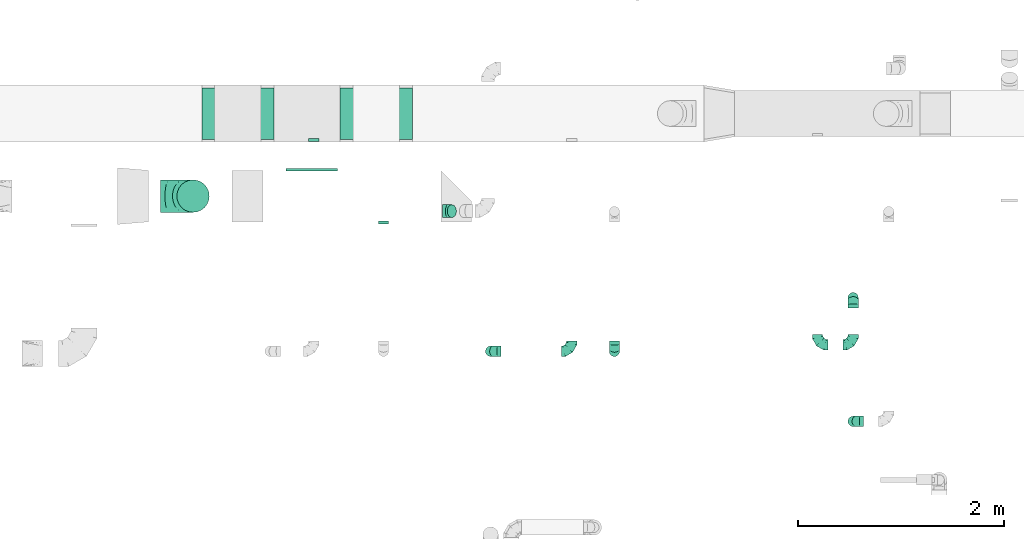
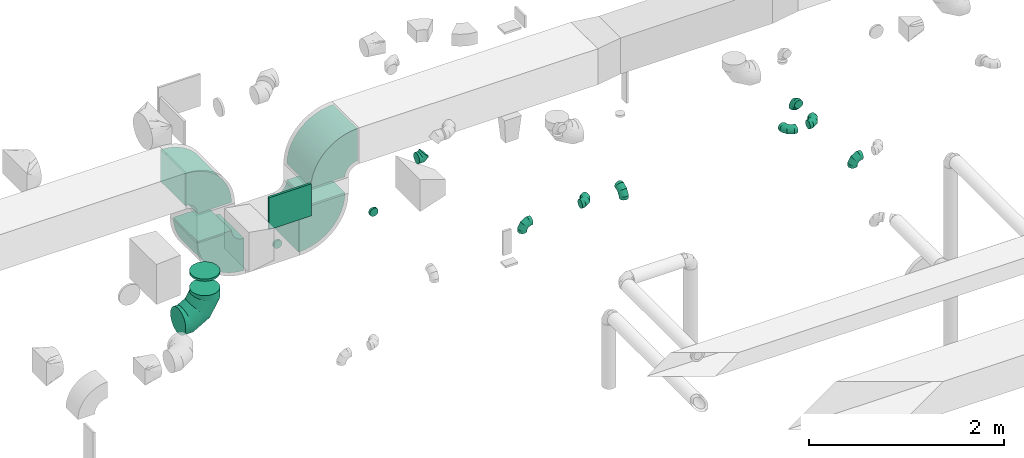
# One storey, part 60 of 97: 17 flow fittings.
"""IFC2X3 building model written with IfcOpenShell, lengths in millimetres."""

from ifc_helpers import new_model, entity, si_unit, converted_unit, derived_unit, direction, frame, frame_2d, origin, origin_2d_with_axis, place, context, subcontext, project, spatial, polyline, circle_curve, parameter, trimmed, segment, composite_curve, rectangle, outline, extrude, faceted_brep, source, transform, mapped, material, type_object, type_shapes, element, save


model = new_model("IFC2X3")

# Units and contexts
model_context = context("Model", 3, precision=0.01, world=origin(), true_north=direction((6.12303176911189e-17, 1.0)))
body_context = subcontext(model_context, "Body", "Model", "MODEL_VIEW")
ifc_project = project(units=[si_unit("LENGTHUNIT", "METRE", prefix="MILLI"), si_unit("AREAUNIT", "SQUARE_METRE"), si_unit("VOLUMEUNIT", "CUBIC_METRE"), converted_unit("PLANEANGLEUNIT", "DEGREE", entity("IfcRatioMeasure", 0.0174532925199433), si_unit("PLANEANGLEUNIT", "RADIAN"), dimensions=[0, 0, 0, 0, 0, 0, 0]), si_unit("MASSUNIT", "GRAM", prefix="KILO"), derived_unit("MASSDENSITYUNIT", [(si_unit("MASSUNIT", "GRAM", prefix="KILO"), 1), (si_unit("LENGTHUNIT", "METRE"), -3)]), derived_unit("MOMENTOFINERTIAUNIT", [(si_unit("LENGTHUNIT", "METRE"), 4)]), si_unit("TIMEUNIT", "SECOND"), si_unit("FREQUENCYUNIT", "HERTZ"), si_unit("THERMODYNAMICTEMPERATUREUNIT", "DEGREE_CELSIUS"), derived_unit("THERMALTRANSMITTANCEUNIT", [(si_unit("MASSUNIT", "GRAM", prefix="KILO"), 1), (si_unit("THERMODYNAMICTEMPERATUREUNIT", "KELVIN"), -1), (si_unit("TIMEUNIT", "SECOND"), -3)]), derived_unit("VOLUMETRICFLOWRATEUNIT", [(si_unit("LENGTHUNIT", "METRE"), 3), (si_unit("TIMEUNIT", "SECOND"), -1)]), derived_unit("MASSFLOWRATEUNIT", [(si_unit("MASSUNIT", "GRAM", prefix="KILO"), 1), (si_unit("TIMEUNIT", "SECOND"), -1)]), derived_unit("ROTATIONALFREQUENCYUNIT", [(si_unit("TIMEUNIT", "SECOND"), -1)]), si_unit("ELECTRICCURRENTUNIT", "AMPERE"), si_unit("ELECTRICVOLTAGEUNIT", "VOLT"), si_unit("POWERUNIT", "WATT"), si_unit("FORCEUNIT", "NEWTON", prefix="KILO"), si_unit("ILLUMINANCEUNIT", "LUX"), si_unit("LUMINOUSFLUXUNIT", "LUMEN"), si_unit("LUMINOUSINTENSITYUNIT", "CANDELA"), derived_unit("USERDEFINED", [(si_unit("MASSUNIT", "GRAM", prefix="KILO"), -1), (si_unit("LENGTHUNIT", "METRE"), -2), (si_unit("TIMEUNIT", "SECOND"), 3), (si_unit("LUMINOUSFLUXUNIT", "LUMEN"), 1)]), derived_unit("LINEARVELOCITYUNIT", [(si_unit("LENGTHUNIT", "METRE"), 1), (si_unit("TIMEUNIT", "SECOND"), -1)]), si_unit("PRESSUREUNIT", "PASCAL"), derived_unit("USERDEFINED", [(si_unit("LENGTHUNIT", "METRE"), -2), (si_unit("MASSUNIT", "GRAM", prefix="KILO"), 1), (si_unit("TIMEUNIT", "SECOND"), -2)]), derived_unit("LINEARFORCEUNIT", [(si_unit("MASSUNIT", "GRAM", prefix="KILO"), 1), (si_unit("LENGTHUNIT", "METRE"), 1), (si_unit("TIMEUNIT", "SECOND"), -2), (si_unit("LENGTHUNIT", "METRE"), -1)]), derived_unit("PLANARFORCEUNIT", [(si_unit("MASSUNIT", "GRAM", prefix="KILO"), 1), (si_unit("LENGTHUNIT", "METRE"), 1), (si_unit("TIMEUNIT", "SECOND"), -2), (si_unit("LENGTHUNIT", "METRE"), -2)])], contexts=[model_context])

# Site, building, storey
site_placement = place(None, origin())
site = spatial("IfcSite", under=ifc_project, at=site_placement, CompositionType="ELEMENT")
building_placement = place(site_placement, origin())
building = spatial("IfcBuilding", under=site, at=building_placement, CompositionType="ELEMENT")
storey_placement = place(building_placement, frame((0.0, 0.0, -4900.0)))
storey = spatial("IfcBuildingStorey", under=building, at=storey_placement, CompositionType="ELEMENT", Elevation=-4900.0)

# Flow fittings
ifc_material = material()
duct_fitting_type_1 = type_object("IfcDuctFittingType", PredefinedType="NOTDEFINED", material=ifc_material)
shared_shape_1 = source(origin(), body_context, "Body", "SweptSolid", [
    extrude(rectangle(XDim=500.0, YDim=26.0960000000433, at=origin_2d_with_axis()), frame((6.95, 0.0, -200.0), z_axis=(0.0, 0.0, 1.0), x_axis=(0.0, -1.0, 0.0)), (0.0, 0.0, 1.0), 400.0),
])
type_shapes(duct_fitting_type_1, [shared_shape_1])
flow_fitting_1_placement = place(storey_placement, frame((49419.33, 14798.39, 3800.0), z_axis=(0.0, 0.0, -1.0), x_axis=(0.0, 1.0, 0.0)))
element("IfcFlowFitting", 1, at=flow_fitting_1_placement, inside=storey, type_object=duct_fitting_type_1, material=ifc_material, context=body_context, shape_type="MappedRepresentation", body=[
    mapped(shared_shape_1, transform((0.0, 0.0, 0.0), scale=1.0)),
])
duct_fitting_type_2 = type_object("IfcDuctFittingType", PredefinedType="NOTDEFINED", material=ifc_material)
shared_shape_2 = source(origin(), body_context, "Body", "Brep", [
    faceted_brep([(-100.0, 0.0, -50.0), (-100.0, -12.94, -48.3), (-100.0, -25.0, -43.3), (-100.0, -35.36, -35.36), (-100.0, -43.3, -25.0), (-100.0, -48.3, -12.94), (-100.0, -50.0, 0.0), (-100.0, -48.3, 12.94), (-100.0, -43.3, 25.0), (-100.0, -35.36, 35.36), (-100.0, -25.0, 43.3), (-100.0, -12.94, 48.3), (-100.0, 0.0, 50.0), (-100.0, 12.94, 48.3), (-100.0, 25.0, 43.3), (-100.0, 35.36, 35.36), (-100.0, 43.3, 25.0), (-100.0, 48.3, 12.94), (-100.0, 50.0, 0.0), (-100.0, 48.3, -12.94), (-100.0, 43.3, -25.0), (-100.0, 35.36, -35.36), (-100.0, 25.0, -43.3), (-100.0, 12.94, -48.3), (-76.67, 12.94, 48.3), (-79.9, 25.0, 43.3), (-73.21, 0.0, 50.0), (-82.68, 35.36, 35.36), (-86.15, 48.3, 12.94), (-86.6, 50.0, 0.0), (-84.81, 43.3, 25.0), (-84.81, 43.3, -25.0), (-82.68, 35.36, -35.36), (-86.15, 48.3, -12.94), (-76.67, 12.94, -48.3), (-73.21, 0.0, -50.0), (-79.9, 25.0, -43.3), (-69.74, -12.94, -48.3), (-66.51, -25.0, -43.3), (-63.73, -35.36, -35.36), (-61.6, -43.3, -25.0), (-60.26, -48.3, -12.94), (-59.81, -50.0, 0.0), (-60.26, -48.3, 12.94), (-61.6, -43.3, 25.0), (-63.73, -35.36, 35.36), (-66.51, -25.0, 43.3), (-69.74, -12.94, 48.3), (-36.27, 36.27, 48.3), (-45.1, 45.1, 43.3), (-26.79, 26.79, 50.0), (-52.68, 52.68, 35.36), (-58.49, 58.49, 25.0), (-62.15, 62.15, 12.94), (-63.4, 63.4, 0.0), (-62.15, 62.15, -12.94), (-58.49, 58.49, -25.0), (-52.68, 52.68, -35.36), (-36.27, 36.27, -48.3), (-26.79, 26.79, -50.0), (-45.1, 45.1, -43.3), (-17.32, 17.32, -48.3), (-8.49, 8.49, -43.3), (-0.91, 0.91, -35.36), (4.9, -4.9, -25.0), (8.56, -8.56, -12.94), (9.81, -9.81, 0.0), (8.56, -8.56, 12.94), (4.9, -4.9, 25.0), (-0.91, 0.91, 35.36), (-8.49, 8.49, 43.3), (-17.32, 17.32, 48.3), (-12.94, 76.67, 48.3), (-25.0, 79.9, 43.3), (0.0, 73.21, 50.0), (-35.36, 82.68, 35.36), (-43.3, 84.81, 25.0), (-48.3, 86.15, 12.94), (-50.0, 86.6, 0.0), (-48.3, 86.15, -12.94), (-43.3, 84.81, -25.0), (-35.36, 82.68, -35.36), (-12.94, 76.67, -48.3), (0.0, 73.21, -50.0), (-25.0, 79.9, -43.3), (12.94, 69.74, -48.3), (25.0, 66.51, -43.3), (35.36, 63.73, -35.36), (43.3, 61.6, -25.0), (48.3, 60.26, -12.94), (50.0, 59.81, 0.0), (48.3, 60.26, 12.94), (43.3, 61.6, 25.0), (35.36, 63.73, 35.36), (25.0, 66.51, 43.3), (12.94, 69.74, 48.3), (-12.94, 100.0, -48.3), (-25.0, 100.0, -43.3), (-35.36, 100.0, -35.36), (-43.3, 100.0, -25.0), (-48.3, 100.0, -12.94), (-50.0, 100.0, 0.0), (-48.3, 100.0, 12.94), (-43.3, 100.0, 25.0), (-35.36, 100.0, 35.36), (-25.0, 100.0, 43.3), (-12.94, 100.0, 48.3), (0.0, 100.0, 50.0), (12.94, 100.0, 48.3), (25.0, 100.0, 43.3), (35.36, 100.0, 35.36), (43.3, 100.0, 25.0), (48.3, 100.0, 12.94), (50.0, 100.0, 0.0), (48.3, 100.0, -12.94), (43.3, 100.0, -25.0), (35.36, 100.0, -35.36), (25.0, 100.0, -43.3), (12.94, 100.0, -48.3), (0.0, 100.0, -50.0)], [[[0, 1, 2, 3, 4, 5, 6, 7, 8, 9, 10, 11, 12, 13, 14, 15, 16, 17, 18, 19, 20, 21, 22, 23]], [[24, 25, 14, 13]], [[26, 24, 13, 12]], [[14, 25, 27, 15]], [[28, 29, 18, 17]], [[30, 28, 17, 16]], [[15, 27, 30, 16]], [[20, 31, 32, 21]], [[33, 31, 20, 19]], [[18, 29, 33, 19]], [[34, 35, 0, 23]], [[36, 34, 23, 22]], [[32, 36, 22, 21]], [[2, 1, 37, 38]], [[3, 2, 38, 39]], [[0, 35, 37, 1]], [[5, 4, 40, 41]], [[6, 5, 41, 42]], [[3, 39, 40, 4]], [[6, 42, 43, 7]], [[7, 43, 44, 8]], [[8, 44, 45, 9]], [[10, 46, 47, 11]], [[11, 47, 26, 12]], [[10, 9, 45, 46]], [[48, 49, 25, 24]], [[50, 48, 24, 26]], [[27, 25, 49, 51]], [[52, 53, 28, 30]], [[51, 52, 30, 27]], [[29, 28, 53, 54]], [[55, 56, 31, 33]], [[54, 55, 33, 29]], [[57, 32, 31, 56]], [[58, 59, 35, 34]], [[60, 58, 34, 36]], [[57, 60, 36, 32]], [[37, 35, 59, 61]], [[38, 37, 61, 62]], [[39, 38, 62, 63]], [[41, 40, 64, 65]], [[42, 41, 65, 66]], [[63, 64, 40, 39]], [[43, 42, 66, 67]], [[44, 43, 67, 68]], [[68, 69, 45, 44]], [[46, 45, 69, 70]], [[47, 46, 70, 71]], [[26, 47, 71, 50]], [[72, 73, 49, 48]], [[74, 72, 48, 50]], [[51, 49, 73, 75]], [[76, 77, 53, 52]], [[75, 76, 52, 51]], [[54, 53, 77, 78]], [[79, 80, 56, 55]], [[78, 79, 55, 54]], [[81, 57, 56, 80]], [[82, 83, 59, 58]], [[84, 82, 58, 60]], [[81, 84, 60, 57]], [[61, 59, 83, 85]], [[62, 61, 85, 86]], [[63, 62, 86, 87]], [[65, 64, 88, 89]], [[66, 65, 89, 90]], [[87, 88, 64, 63]], [[67, 66, 90, 91]], [[68, 67, 91, 92]], [[92, 93, 69, 68]], [[70, 69, 93, 94]], [[71, 70, 94, 95]], [[50, 71, 95, 74]], [[96, 97, 98, 99, 100, 101, 102, 103, 104, 105, 106, 107, 108, 109, 110, 111, 112, 113, 114, 115, 116, 117, 118, 119]], [[72, 74, 107, 106]], [[73, 72, 106, 105]], [[75, 73, 105, 104]], [[77, 76, 103, 102]], [[78, 77, 102, 101]], [[75, 104, 103, 76]], [[78, 101, 100, 79]], [[79, 100, 99, 80]], [[80, 99, 98, 81]], [[96, 119, 83, 82]], [[97, 96, 82, 84]], [[84, 81, 98, 97]], [[83, 119, 118, 85]], [[85, 118, 117, 86]], [[86, 117, 116, 87]], [[88, 115, 114, 89]], [[89, 114, 113, 90]], [[87, 116, 115, 88]], [[91, 90, 113, 112]], [[92, 91, 112, 111]], [[93, 92, 111, 110]], [[95, 94, 109, 108]], [[74, 95, 108, 107]], [[110, 109, 94, 93]]]),
])
type_shapes(duct_fitting_type_2, [shared_shape_2])
flow_fitting_2_placement = place(storey_placement, frame((51154.01, 13043.4, 4050.0), z_axis=(0.0, -1.0, 0.0), x_axis=(-1.0, 0.0, 0.0)))
element("IfcFlowFitting", 2, at=flow_fitting_2_placement, inside=storey, type_object=duct_fitting_type_2, material=ifc_material, context=body_context, shape_type="MappedRepresentation", body=[
    mapped(shared_shape_2, transform((0.0, 0.0, 0.0), scale=1.0)),
])
flow_fitting_3_placement = place(storey_placement, frame((54669.17, 13105.52, 4050.0)))
element("IfcFlowFitting", 3, at=flow_fitting_3_placement, inside=storey, type_object=duct_fitting_type_2, material=ifc_material, context=body_context, shape_type="MappedRepresentation", body=[
    mapped(shared_shape_2, transform((0.0, 0.0, 0.0), scale=1.0)),
])
for number, where, z_axis, x_axis in (
    (4, (54669.17, 13563.56, 4050.0), (-1.0, 0.0, 0.0), (0.0, 1.0, 0.0)),
    (5, (54669.17, 12363.56, 4050.0), (0.0, -1.0, 0.0), (-1.0, 0.0, 0.0)),
):
    element("IfcFlowFitting", number, at=place(storey_placement, frame(where, z_axis=z_axis, x_axis=x_axis)), inside=storey, type_object=duct_fitting_type_2, material=ifc_material, context=body_context, shape_type="MappedRepresentation", body=[
        mapped(shared_shape_2, transform((0.0, 0.0, 0.0), scale=1.0)),
    ])
flow_fitting_4_placement = place(storey_placement, frame((51939.09, 13043.4, 4050.0)))
element("IfcFlowFitting", 6, at=flow_fitting_4_placement, inside=storey, type_object=duct_fitting_type_2, material=ifc_material, context=body_context, shape_type="MappedRepresentation", body=[
    mapped(shared_shape_2, transform((0.0, 0.0, 0.0), scale=1.0)),
])
for number, where, z_axis, x_axis in (
    (7, (54324.51, 13105.52, 4050.0), (0.0, 0.0, 1.0), (0.0, -1.0, 0.0)),
    (8, (52354.62, 13043.39, 4050.0), (-1.0, 0.0, 0.0), (0.0, 0.0, 1.0)),
):
    element("IfcFlowFitting", number, at=place(storey_placement, frame(where, z_axis=z_axis, x_axis=x_axis)), inside=storey, type_object=duct_fitting_type_2, material=ifc_material, context=body_context, shape_type="MappedRepresentation", body=[
        mapped(shared_shape_2, transform((0.0, 0.0, 0.0), scale=1.0)),
    ])
duct_fitting_type_3 = type_object("IfcDuctFittingType", PredefinedType="NOTDEFINED", material=ifc_material)
shared_shape_3 = source(origin(), body_context, "Body", "Brep", [
    faceted_brep([(-51.78, 0.0, -62.5), (-51.78, -16.18, -60.37), (-51.78, -31.25, -54.13), (-51.78, -44.19, -44.19), (-51.78, -54.13, -31.25), (-51.78, -60.37, -16.18), (-51.78, -62.5, 0.0), (-51.78, -60.37, 16.18), (-51.78, -54.13, 31.25), (-51.78, -44.19, 44.19), (-51.78, -31.25, 54.13), (-51.78, -16.18, 60.37), (-51.78, 0.0, 62.5), (-51.78, 16.18, 60.37), (-51.78, 31.25, 54.13), (-51.78, 44.19, 44.19), (-51.78, 54.13, 31.25), (-51.78, 60.37, 16.18), (-51.78, 62.5, 0.0), (-51.78, 60.37, -16.18), (-51.78, 54.13, -31.25), (-51.78, 44.19, -44.19), (-51.78, 31.25, -54.13), (-51.78, 16.18, -60.37), (-6.7, 16.18, 60.37), (-12.94, 31.25, 54.13), (0.0, 0.0, 62.5), (-18.31, 44.19, 44.19), (-22.42, 54.13, 31.25), (-25.01, 60.37, 16.18), (-25.89, 62.5, 0.0), (-25.01, 60.37, -16.18), (-22.42, 54.13, -31.25), (-18.31, 44.19, -44.19), (-6.7, 16.18, -60.37), (0.0, 0.0, -62.5), (-12.94, 31.25, -54.13), (6.7, -16.18, -60.37), (12.94, -31.25, -54.13), (18.31, -44.19, -44.19), (22.42, -54.13, -31.25), (25.01, -60.37, -16.18), (25.89, -62.5, 0.0), (25.01, -60.37, 16.18), (22.42, -54.13, 31.25), (18.31, -44.19, 44.19), (12.94, -31.25, 54.13), (6.7, -16.18, 60.37), (25.17, 48.05, 60.37), (14.51, 58.71, 54.13), (36.61, 36.61, 62.5), (5.36, 67.86, 44.19), (-1.66, 74.88, 31.25), (-6.08, 79.3, 16.18), (-7.58, 80.81, 0.0), (-6.08, 79.3, -16.18), (-1.66, 74.88, -31.25), (5.36, 67.86, -44.19), (14.51, 58.71, -54.13), (25.17, 48.05, -60.37), (36.61, 36.61, -62.5), (48.05, 25.17, -60.37), (58.71, 14.51, -54.13), (67.86, 5.36, -44.19), (74.88, -1.66, -31.25), (79.3, -6.08, -16.18), (80.81, -7.58, 0.0), (79.3, -6.08, 16.18), (74.88, -1.66, 31.25), (67.86, 5.36, 44.19), (58.71, 14.51, 54.13), (48.05, 25.17, 60.37)], [[[0, 1, 2, 3, 4, 5, 6, 7, 8, 9, 10, 11, 12, 13, 14, 15, 16, 17, 18, 19, 20, 21, 22, 23]], [[24, 25, 14, 13]], [[26, 24, 13, 12]], [[27, 15, 14, 25]], [[28, 29, 17, 16]], [[28, 16, 15, 27]], [[30, 18, 17, 29]], [[31, 32, 20, 19]], [[30, 31, 19, 18]], [[21, 20, 32, 33]], [[34, 35, 0, 23]], [[36, 34, 23, 22]], [[33, 36, 22, 21]], [[1, 0, 35, 37]], [[2, 1, 37, 38]], [[38, 39, 3, 2]], [[5, 4, 40, 41]], [[6, 5, 41, 42]], [[39, 40, 4, 3]], [[6, 42, 43, 7]], [[7, 43, 44, 8]], [[8, 44, 45, 9]], [[9, 45, 46, 10]], [[10, 46, 47, 11]], [[26, 12, 11, 47]], [[48, 49, 25, 24]], [[50, 48, 24, 26]], [[27, 25, 49, 51]], [[29, 28, 52, 53]], [[30, 29, 53, 54]], [[51, 52, 28, 27]], [[30, 54, 55, 31]], [[31, 55, 56, 32]], [[57, 33, 32, 56]], [[36, 58, 59, 34]], [[34, 59, 60, 35]], [[58, 36, 33, 57]], [[35, 60, 61, 37]], [[37, 61, 62, 38]], [[63, 39, 38, 62]], [[40, 64, 65, 41]], [[41, 65, 66, 42]], [[64, 40, 39, 63]], [[43, 42, 66, 67]], [[44, 43, 67, 68]], [[68, 69, 45, 44]], [[47, 46, 70, 71]], [[26, 47, 71, 50]], [[69, 70, 46, 45]], [[59, 58, 57, 56, 55, 54, 53, 52, 51, 49, 48, 50, 71, 70, 69, 68, 67, 66, 65, 64, 63, 62, 61, 60]]]),
])
type_shapes(duct_fitting_type_3, [shared_shape_3])
flow_fitting_5_placement = place(storey_placement, frame((50740.64, 14402.31, 4200.0), z_axis=(0.0, 1.0, 0.0), x_axis=(-0.707106781186509, 0.0, -0.707106781186586)))
element("IfcFlowFitting", 9, at=flow_fitting_5_placement, inside=storey, type_object=duct_fitting_type_3, material=ifc_material, context=body_context, shape_type="MappedRepresentation", body=[
    mapped(shared_shape_3, transform((0.0, 0.0, 0.0), scale=1.0)),
])
duct_fitting_type_4 = type_object("IfcDuctFittingType", PredefinedType="NOTDEFINED", material=ifc_material)
shared_shape_4 = source(origin(), body_context, "Body", "Brep", [
    faceted_brep([(20.0, 12.94, -48.3), (20.0, 25.0, -43.3), (20.0, 35.36, -35.36), (20.0, 43.3, -25.0), (20.0, 48.3, -12.94), (20.0, 50.0, 0.0), (20.0, 48.3, 12.94), (20.0, 43.3, 25.0), (20.0, 35.36, 35.36), (20.0, 25.0, 43.3), (20.0, 12.94, 48.3), (20.0, 0.0, 50.0), (20.0, -12.94, 48.3), (20.0, -25.0, 43.3), (20.0, -35.36, 35.36), (20.0, -43.3, 25.0), (20.0, -48.3, 12.94), (20.0, -50.0, 0.0), (20.0, -48.3, -12.94), (20.0, -43.3, -25.0), (20.0, -35.36, -35.36), (20.0, -25.0, -43.3), (20.0, -12.94, -48.3), (20.0, 0.0, -50.0), (0.0, 0.0, 50.0), (0.0, 12.94, 48.3), (-6.1, 12.94, 48.3), (-6.1, 0.0, 50.0), (0.0, 25.0, 43.3), (-6.1, 25.0, 43.3), (0.0, 35.36, 35.36), (-6.1, 35.36, 35.36), (0.0, 43.3, 25.0), (0.0, 48.3, 12.94), (-6.1, 48.3, 12.94), (-6.1, 43.3, 25.0), (0.0, 50.0, 0.0), (-6.1, 50.0, 0.0), (0.0, 48.3, -12.94), (-6.1, 48.3, -12.94), (0.0, 43.3, -25.0), (-6.1, 43.3, -25.0), (0.0, 35.36, -35.36), (-6.1, 35.36, -35.36), (0.0, 25.0, -43.3), (0.0, 12.94, -48.3), (-6.1, 12.94, -48.3), (-6.1, 25.0, -43.3), (0.0, 0.0, -50.0), (-6.1, 0.0, -50.0), (0.0, -12.94, -48.3), (-6.1, -12.94, -48.3), (0.0, -25.0, -43.3), (-6.1, -25.0, -43.3), (0.0, -35.36, -35.36), (-6.1, -35.36, -35.36), (0.0, -43.3, -25.0), (0.0, -48.3, -12.94), (-6.1, -48.3, -12.94), (-6.1, -43.3, -25.0), (0.0, -50.0, 0.0), (-6.1, -50.0, 0.0), (0.0, -48.3, 12.94), (-6.1, -48.3, 12.94), (0.0, -43.3, 25.0), (-6.1, -43.3, 25.0), (0.0, -35.36, 35.36), (-6.1, -35.36, 35.36), (0.0, -25.0, 43.3), (0.0, -12.94, 48.3), (-6.1, -12.94, 48.3), (-6.1, -25.0, 43.3)], [[[0, 1, 2, 3, 4, 5, 6, 7, 8, 9, 10, 11, 12, 13, 14, 15, 16, 17, 18, 19, 20, 21, 22, 23]], [[24, 11, 10, 25, 26, 27]], [[25, 10, 9, 28, 29, 26]], [[28, 9, 8, 30, 31, 29]], [[32, 7, 6, 33, 34, 35]], [[33, 6, 5, 36, 37, 34]], [[30, 8, 7, 32, 35, 31]], [[36, 5, 4, 38, 39, 37]], [[38, 4, 3, 40, 41, 39]], [[40, 3, 2, 42, 43, 41]], [[44, 1, 0, 45, 46, 47]], [[45, 0, 23, 48, 49, 46]], [[42, 2, 1, 44, 47, 43]], [[48, 23, 22, 50, 51, 49]], [[50, 22, 21, 52, 53, 51]], [[52, 21, 20, 54, 55, 53]], [[56, 19, 18, 57, 58, 59]], [[57, 18, 17, 60, 61, 58]], [[54, 20, 19, 56, 59, 55]], [[60, 17, 16, 62, 63, 61]], [[62, 16, 15, 64, 65, 63]], [[64, 15, 14, 66, 67, 65]], [[68, 13, 12, 69, 70, 71]], [[69, 12, 11, 24, 27, 70]], [[66, 14, 13, 68, 71, 67]], [[49, 51, 53, 55, 59, 58, 61, 63, 65, 67, 71, 70, 27, 26, 29, 31, 35, 34, 37, 39, 41, 43, 47, 46]]]),
])
type_shapes(duct_fitting_type_4, [shared_shape_4])
for number, where, z_axis, x_axis in (
    (10, (50114.62, 14298.39, 3800.0), (0.0, 0.0, -1.0), (0.0, -1.0, 0.0)),
    (11, (49439.09, 15098.96, 3150.0), (0.0, 0.0, -1.0), (0.0, -1.0, 0.0)),
):
    element("IfcFlowFitting", number, at=place(storey_placement, frame(where, z_axis=z_axis, x_axis=x_axis)), inside=storey, type_object=duct_fitting_type_4, material=ifc_material, context=body_context, shape_type="MappedRepresentation", body=[
        mapped(shared_shape_4, transform((0.0, 0.0, 0.0), scale=1.0)),
    ])
duct_fitting_type_5 = type_object("IfcDuctFittingType", PredefinedType="NOTDEFINED", material=ifc_material)
shared_shape_5 = source(origin(), body_context, "Body", "Brep", [
    faceted_brep([(-315.0, 0.0, -157.5), (-315.0, -40.76, -152.13), (-315.0, -78.75, -136.4), (-315.0, -111.37, -111.37), (-315.0, -136.4, -78.75), (-315.0, -152.13, -40.76), (-315.0, -157.5, 0.0), (-315.0, -152.13, 40.76), (-315.0, -136.4, 78.75), (-315.0, -111.37, 111.37), (-315.0, -78.75, 136.4), (-315.0, -40.76, 152.13), (-315.0, 0.0, 157.5), (-315.0, 40.76, 152.13), (-315.0, 78.75, 136.4), (-315.0, 111.37, 111.37), (-315.0, 136.4, 78.75), (-315.0, 152.13, 40.76), (-315.0, 157.5, 0.0), (-315.0, 152.13, -40.76), (-315.0, 136.4, -78.75), (-315.0, 111.37, -111.37), (-315.0, 78.75, -136.4), (-315.0, 40.76, -152.13), (-241.52, 40.76, 152.13), (-251.7, 78.75, 136.4), (-230.6, 0.0, 157.5), (-260.44, 111.37, 111.37), (-271.36, 152.13, 40.76), (-272.8, 157.5, 0.0), (-267.14, 136.4, 78.75), (-267.14, 136.4, -78.75), (-260.44, 111.37, -111.37), (-271.36, 152.13, -40.76), (-241.52, 40.76, -152.13), (-230.6, 0.0, -157.5), (-251.7, 78.75, -136.4), (-219.67, -40.76, -152.13), (-209.5, -78.75, -136.4), (-200.75, -111.37, -111.37), (-194.05, -136.4, -78.75), (-189.83, -152.13, -40.76), (-188.39, -157.5, 0.0), (-189.83, -152.13, 40.76), (-194.05, -136.4, 78.75), (-200.75, -111.37, 111.37), (-209.5, -78.75, 136.4), (-219.67, -40.76, 152.13), (-114.25, 114.25, 152.13), (-142.05, 142.05, 136.4), (-84.4, 84.4, 157.5), (-165.93, 165.93, 111.37), (-184.25, 184.25, 78.75), (-195.77, 195.77, 40.76), (-199.7, 199.7, 0.0), (-195.77, 195.77, -40.76), (-184.25, 184.25, -78.75), (-165.93, 165.93, -111.37), (-114.25, 114.25, -152.13), (-84.4, 84.4, -157.5), (-142.05, 142.05, -136.4), (-54.56, 54.56, -152.13), (-26.75, 26.75, -136.4), (-2.88, 2.88, -111.37), (15.45, -15.45, -78.75), (26.97, -26.97, -40.76), (30.89, -30.89, 0.0), (26.97, -26.97, 40.76), (15.45, -15.45, 78.75), (-2.88, 2.88, 111.37), (-26.75, 26.75, 136.4), (-54.56, 54.56, 152.13), (-40.76, 241.52, 152.13), (-78.75, 251.7, 136.4), (0.0, 230.6, 157.5), (-111.37, 260.44, 111.37), (-136.4, 267.14, 78.75), (-152.13, 271.36, 40.76), (-157.5, 272.8, 0.0), (-152.13, 271.36, -40.76), (-136.4, 267.14, -78.75), (-111.37, 260.44, -111.37), (-40.76, 241.52, -152.13), (0.0, 230.6, -157.5), (-78.75, 251.7, -136.4), (40.76, 219.67, -152.13), (78.75, 209.5, -136.4), (111.37, 200.75, -111.37), (136.4, 194.05, -78.75), (152.13, 189.83, -40.76), (157.5, 188.39, 0.0), (152.13, 189.83, 40.76), (136.4, 194.05, 78.75), (111.37, 200.75, 111.37), (78.75, 209.5, 136.4), (40.76, 219.67, 152.13), (-40.76, 315.0, -152.13), (-78.75, 315.0, -136.4), (-111.37, 315.0, -111.37), (-136.4, 315.0, -78.75), (-152.13, 315.0, -40.76), (-157.5, 315.0, 0.0), (-152.13, 315.0, 40.76), (-136.4, 315.0, 78.75), (-111.37, 315.0, 111.37), (-78.75, 315.0, 136.4), (-40.76, 315.0, 152.13), (0.0, 315.0, 157.5), (40.76, 315.0, 152.13), (78.75, 315.0, 136.4), (111.37, 315.0, 111.37), (136.4, 315.0, 78.75), (152.13, 315.0, 40.76), (157.5, 315.0, 0.0), (152.13, 315.0, -40.76), (136.4, 315.0, -78.75), (111.37, 315.0, -111.37), (78.75, 315.0, -136.4), (40.76, 315.0, -152.13), (0.0, 315.0, -157.5)], [[[0, 1, 2, 3, 4, 5, 6, 7, 8, 9, 10, 11, 12, 13, 14, 15, 16, 17, 18, 19, 20, 21, 22, 23]], [[24, 25, 14, 13]], [[26, 24, 13, 12]], [[14, 25, 27, 15]], [[28, 29, 18, 17]], [[30, 28, 17, 16]], [[15, 27, 30, 16]], [[20, 31, 32, 21]], [[33, 31, 20, 19]], [[18, 29, 33, 19]], [[34, 35, 0, 23]], [[36, 34, 23, 22]], [[32, 36, 22, 21]], [[1, 0, 35, 37]], [[2, 1, 37, 38]], [[38, 39, 3, 2]], [[5, 4, 40, 41]], [[6, 5, 41, 42]], [[39, 40, 4, 3]], [[6, 42, 43, 7]], [[7, 43, 44, 8]], [[8, 44, 45, 9]], [[9, 45, 46, 10]], [[10, 46, 47, 11]], [[26, 12, 11, 47]], [[48, 49, 25, 24]], [[50, 48, 24, 26]], [[27, 25, 49, 51]], [[52, 53, 28, 30]], [[51, 52, 30, 27]], [[29, 28, 53, 54]], [[55, 56, 31, 33]], [[54, 55, 33, 29]], [[32, 31, 56, 57]], [[58, 59, 35, 34]], [[60, 58, 34, 36]], [[57, 60, 36, 32]], [[37, 35, 59, 61]], [[38, 37, 61, 62]], [[39, 38, 62, 63]], [[41, 40, 64, 65]], [[42, 41, 65, 66]], [[63, 64, 40, 39]], [[43, 42, 66, 67]], [[44, 43, 67, 68]], [[68, 69, 45, 44]], [[46, 45, 69, 70]], [[47, 46, 70, 71]], [[26, 47, 71, 50]], [[72, 73, 49, 48]], [[74, 72, 48, 50]], [[51, 49, 73, 75]], [[76, 77, 53, 52]], [[75, 76, 52, 51]], [[54, 53, 77, 78]], [[79, 80, 56, 55]], [[78, 79, 55, 54]], [[57, 56, 80, 81]], [[82, 83, 59, 58]], [[84, 82, 58, 60]], [[81, 84, 60, 57]], [[61, 59, 83, 85]], [[62, 61, 85, 86]], [[63, 62, 86, 87]], [[65, 64, 88, 89]], [[66, 65, 89, 90]], [[87, 88, 64, 63]], [[67, 66, 90, 91]], [[68, 67, 91, 92]], [[92, 93, 69, 68]], [[70, 69, 93, 94]], [[71, 70, 94, 95]], [[50, 71, 95, 74]], [[96, 97, 98, 99, 100, 101, 102, 103, 104, 105, 106, 107, 108, 109, 110, 111, 112, 113, 114, 115, 116, 117, 118, 119]], [[106, 105, 73, 72]], [[107, 106, 72, 74]], [[75, 73, 105, 104]], [[77, 76, 103, 102]], [[78, 77, 102, 101]], [[104, 103, 76, 75]], [[78, 101, 100, 79]], [[79, 100, 99, 80]], [[98, 81, 80, 99]], [[84, 97, 96, 82]], [[82, 96, 119, 83]], [[97, 84, 81, 98]], [[83, 119, 118, 85]], [[85, 118, 117, 86]], [[116, 87, 86, 117]], [[88, 115, 114, 89]], [[89, 114, 113, 90]], [[115, 88, 87, 116]], [[91, 90, 113, 112]], [[92, 91, 112, 111]], [[111, 110, 93, 92]], [[95, 94, 109, 108]], [[74, 95, 108, 107]], [[110, 109, 94, 93]]]),
])
type_shapes(duct_fitting_type_5, [shared_shape_5])
flow_fitting_6_placement = place(storey_placement, frame((48267.66, 14548.39, 3035.0), z_axis=(0.0, -1.0, 0.0), x_axis=(1.0, 0.0, 0.0)))
element("IfcFlowFitting", 12, at=flow_fitting_6_placement, inside=storey, type_object=duct_fitting_type_5, material=ifc_material, context=body_context, shape_type="MappedRepresentation", body=[
    mapped(shared_shape_5, transform((0.0, 0.0, 0.0), scale=1.0)),
])
duct_fitting_type_6 = type_object("IfcDuctFittingType", PredefinedType="NOTDEFINED", material=ifc_material)
shared_shape_6 = source(origin(), body_context, "Body", "Brep", [
    faceted_brep([(20.0, 0.0, -157.5), (20.0, 40.76, -152.13), (20.0, 78.75, -136.4), (20.0, 111.37, -111.37), (20.0, 136.4, -78.75), (20.0, 152.13, -40.76), (20.0, 157.5, 0.0), (20.0, 152.13, 40.76), (20.0, 136.4, 78.75), (20.0, 111.37, 111.37), (20.0, 78.75, 136.4), (20.0, 40.76, 152.13), (20.0, 0.0, 157.5), (20.0, -40.76, 152.13), (20.0, -78.75, 136.4), (20.0, -111.37, 111.37), (20.0, -136.4, 78.75), (20.0, -152.13, 40.76), (20.0, -157.5, 0.0), (20.0, -152.13, -40.76), (20.0, -136.4, -78.75), (20.0, -111.37, -111.37), (20.0, -78.75, -136.4), (20.0, -40.76, -152.13), (0.0, 0.0, 157.5), (-6.1, 0.0, 157.5), (-6.1, -40.76, 152.13), (0.0, -40.76, 152.13), (-6.1, -78.75, 136.4), (0.0, -78.75, 136.4), (0.0, -111.37, 111.37), (-6.1, -111.37, 111.37), (0.0, -136.4, 78.75), (-6.1, -136.4, 78.75), (-6.1, -152.13, 40.76), (0.0, -152.13, 40.76), (-6.1, -157.5, 0.0), (0.0, -157.5, 0.0), (-6.1, -152.13, -40.76), (0.0, -152.13, -40.76), (-6.1, -136.4, -78.75), (0.0, -136.4, -78.75), (0.0, -111.37, -111.37), (-6.1, -111.37, -111.37), (0.0, 0.0, -157.5), (0.0, -40.76, -152.13), (-6.1, -40.76, -152.13), (-6.1, 0.0, -157.5), (0.0, -78.75, -136.4), (-6.1, -78.75, -136.4), (-6.1, 40.76, -152.13), (0.0, 40.76, -152.13), (-6.1, 78.75, -136.4), (0.0, 78.75, -136.4), (0.0, 111.37, -111.37), (-6.1, 111.37, -111.37), (0.0, 136.4, -78.75), (-6.1, 136.4, -78.75), (-6.1, 152.13, -40.76), (0.0, 152.13, -40.76), (-6.1, 157.5, 0.0), (0.0, 157.5, 0.0), (-6.1, 152.13, 40.76), (0.0, 152.13, 40.76), (-6.1, 136.4, 78.75), (0.0, 136.4, 78.75), (0.0, 111.37, 111.37), (-6.1, 111.37, 111.37), (0.0, 78.75, 136.4), (-6.1, 78.75, 136.4), (-6.1, 40.76, 152.13), (0.0, 40.76, 152.13)], [[[0, 1, 2, 3, 4, 5, 6, 7, 8, 9, 10, 11, 12, 13, 14, 15, 16, 17, 18, 19, 20, 21, 22, 23]], [[13, 12, 24, 25, 26, 27]], [[14, 13, 27, 26, 28, 29]], [[30, 15, 14, 29, 28, 31]], [[17, 16, 32, 33, 34, 35]], [[18, 17, 35, 34, 36, 37]], [[32, 16, 15, 30, 31, 33]], [[19, 18, 37, 36, 38, 39]], [[20, 19, 39, 38, 40, 41]], [[42, 21, 20, 41, 40, 43]], [[44, 0, 23, 45, 46, 47]], [[48, 49, 46, 45, 23, 22]], [[22, 21, 42, 43, 49, 48]], [[1, 0, 44, 47, 50, 51]], [[2, 1, 51, 50, 52, 53]], [[54, 3, 2, 53, 52, 55]], [[5, 4, 56, 57, 58, 59]], [[6, 5, 59, 58, 60, 61]], [[56, 4, 3, 54, 55, 57]], [[7, 6, 61, 60, 62, 63]], [[8, 7, 63, 62, 64, 65]], [[66, 9, 8, 65, 64, 67]], [[11, 10, 68, 69, 70, 71]], [[12, 11, 71, 70, 25, 24]], [[68, 10, 9, 66, 67, 69]], [[46, 49, 43, 40, 38, 36, 34, 33, 31, 28, 26, 25, 70, 69, 67, 64, 62, 60, 58, 57, 55, 52, 50, 47]]]),
])
type_shapes(duct_fitting_type_6, [shared_shape_6])
flow_fitting_7_placement = place(storey_placement, frame((48267.66, 14548.39, 3550.0), z_axis=(1.0, 0.0, 0.0), x_axis=(0.0, 0.0, -1.0)))
element("IfcFlowFitting", 13, at=flow_fitting_7_placement, inside=storey, type_object=duct_fitting_type_6, material=ifc_material, context=body_context, shape_type="MappedRepresentation", body=[
    mapped(shared_shape_6, transform((0.0, 0.0, 0.0), scale=1.0)),
])
duct_fitting_type_7 = type_object("IfcDuctFittingType", PredefinedType="NOTDEFINED", material=ifc_material)
shared_shape_7 = source(origin(), body_context, "Body", "SweptSolid", [
    extrude(outline(composite_curve([segment(polyline([(-375.0, -175.0), (25.0, -175.0)]), True, "CONTINUOUS"), segment(trimmed(circle_curve(frame_2d((175.0, -175.0), x_axis=(0.0, 1.0)), 150.0), [parameter(0.0)], [parameter(90.0000000000001)], True, "PARAMETER"), False, "CONTINUOUS"), segment(polyline([(175.0, -25.0), (175.0, 375.0)]), True, "CONTINUOUS"), segment(trimmed(circle_curve(frame_2d((175.0, -175.0), x_axis=(0.0, 1.0)), 550.0), [parameter(0.0)], [parameter(90.0)], True, "PARAMETER"), True, "CONTINUOUS")], self_intersect=False)), frame((-175.0, 175.0, -250.0), z_axis=(0.0, 0.0, 1.0), x_axis=(-1.0, 0.0, 0.0)), (0.0, 0.0, 1.0), 500.0),
])
type_shapes(duct_fitting_type_7, [shared_shape_7])
for number, where, z_axis, x_axis in (
    (14, (48702.19, 15349.1, 4200.0), (0.0, 1.0, 0.0), (1.0, 0.0, 0.0)),
    (15, (48702.19, 15348.96, 3150.0), (0.0, -1.0, 0.0), (0.0, 0.0, -1.0)),
    (16, (50045.13, 15348.96, 3150.0), (0.0, -1.0, 0.0), (1.0, 0.0, 0.0)),
    (17, (50045.13, 15348.96, 4050.0), (0.0, 1.0, 0.0), (0.0, 0.0, 1.0)),
):
    element("IfcFlowFitting", number, at=place(storey_placement, frame(where, z_axis=z_axis, x_axis=x_axis)), inside=storey, type_object=duct_fitting_type_7, material=ifc_material, context=body_context, shape_type="MappedRepresentation", body=[
        mapped(shared_shape_7, transform((0.0, 0.0, 0.0), scale=1.0)),
    ])

save(model, "model.ifc")
